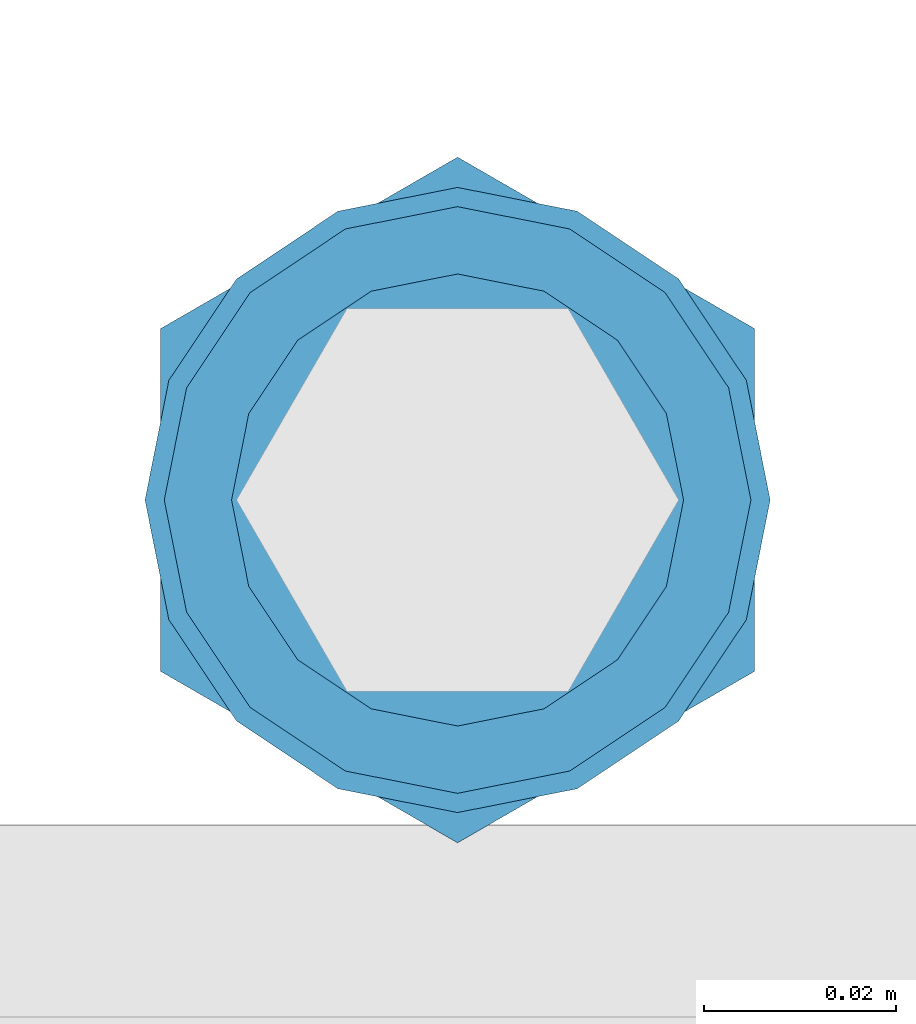
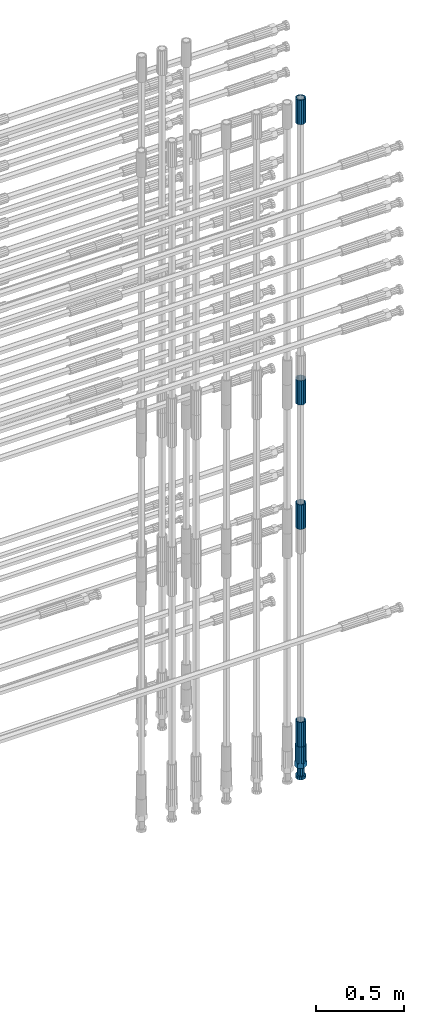
# One storey, part 102 of 119: 5 beams.
"""IFC2X3 building model written with IfcOpenShell, lengths in millimetres."""

from ifc_helpers import new_model, si_unit, frame, origin_with_axes, place, context, subcontext, project, spatial, faceted_brep, material, type_object, element, save


model = new_model("IFC2X3")

# Units and contexts
model_context = context("Model", 3, precision=1e-05, world=origin_with_axes())
body_context = subcontext(model_context, "Body", "Model", "MODEL_VIEW")
ifc_project = project(units=[si_unit("LENGTHUNIT", "METRE", prefix="MILLI"), si_unit("AREAUNIT", "SQUARE_METRE"), si_unit("VOLUMEUNIT", "CUBIC_METRE"), si_unit("MASSUNIT", "GRAM", prefix="KILO"), si_unit("TIMEUNIT", "SECOND"), si_unit("PLANEANGLEUNIT", "RADIAN"), si_unit("SOLIDANGLEUNIT", "STERADIAN"), si_unit("THERMODYNAMICTEMPERATUREUNIT", "DEGREE_CELSIUS"), si_unit("LUMINOUSINTENSITYUNIT", "LUMEN")], contexts=[model_context])

# Site, building, storey
site_placement = place(None, origin_with_axes())
site = spatial("IfcSite", under=ifc_project, at=site_placement, CompositionType="ELEMENT")
building_placement = place(site_placement, origin_with_axes())
building = spatial("IfcBuilding", under=site, at=building_placement, Name="Undefined", CompositionType="ELEMENT")
storey_placement = place(building_placement, origin_with_axes())
storey = spatial("IfcBuildingStorey", under=building, at=storey_placement, Name="Undefined", CompositionType="ELEMENT", Elevation=0.0)

# Beams
ifc_material = material(Name="STEEL/S275")
beam_type_1 = type_object("IfcBeamType", PredefinedType="NOTDEFINED")
beam_1_placement = place(storey_placement, frame((2039119.0136987, 6205156.73095221, 18490.9668583139), z_axis=(-0.99999999999998, 1.98000110685822e-07, 0.0), x_axis=(0.0, 0.0, -1.0)))
element("IfcBeam", 1, at=beam_1_placement, inside=storey, type_object=beam_type_1, material=ifc_material, Name="AG40N", context=body_context, shape_type="Brep", body=[
    faceted_brep([(1.62981450557709e-09, -23.4999999990687, 0.0), (7.45058059692383e-09, -21.7111690142192, 8.99306066057534), (170.000002125278, -21.711168999318, 8.99306066022245), (170.000002127141, -23.4999999844003, -3.66071617463604e-10), (4.65661287307739e-09, -16.6170093587134, 16.6170093578889), (170.000002122484, -16.6170093440451, 16.6170093575288), (1.86264514923096e-09, -8.99306066217832, 21.7111690140277), (170.000002118759, -8.99306064750999, 21.7111690136603), (2.3283064365387e-10, 9.31322574615479e-10, 23.5), (170.000002114102, 1.28056854009628e-08, 23.4999999996485), (-6.51925802230835e-09, 8.99306065868586, 21.7111690140241), (170.00000211224, 8.99306067335419, 21.7111690136639), (-7.45058059692383e-09, 16.6170093561523, 16.6170093578853), (170.000002109446, 16.6170093708206, 16.6170093575324), (-9.31322574615479e-09, 21.711169013055, 8.99306066057534), (170.000002108514, 21.7111690277234, 8.99306066022245), (-1.16415321826935e-09, 23.5000000009313, 0.0), (170.000002108514, 23.5000000144355, -3.66071617463604e-10), (-8.38190317153931e-09, 21.7111690151505, -8.99306066059444), (170.000002110377, 21.7111690300517, -8.9930606609546), (-5.58793544769287e-09, 16.6170093598776, -16.6170093579008), (170.000002113171, 16.6170093745459, -16.6170093582609), (-9.31322574615479e-10, 8.99306066334248, -21.7111690140396), (170.000002115965, 8.99306067801081, -21.7111690143961), (2.3283064365387e-10, 9.31322574615479e-10, -23.5), (170.00000211969, 1.7927959561348e-08, -23.5000000003843), (5.58793544769287e-09, -8.99306065752171, -21.7111690140396), (170.000002123415, -8.99306064285338, -21.7111690143961), (8.38190317153931e-09, -16.6170093549881, -16.6170093579008), (170.000002125278, -16.6170093403198, -16.6170093582646), (9.31322574615479e-09, -21.7111690121237, -8.99306066059444), (170.000002127141, -21.7111689972226, -8.9930606609546), (1.11758708953857e-08, -30.4999999990687, -9.54969436861575e-12), (1.30385160446167e-08, -28.1783257392235, -11.6718446871514), (170.000002129003, -28.1783257243223, -11.6718446875116), (170.000002129935, -30.4999999841675, -3.66071617463604e-10), (1.02445483207703e-08, -21.5667568228673, -21.5667568262129), (170.000002128072, -21.566756808199, -21.5667568265694), (7.45058059692383e-09, -11.6718446831219, -28.1783257416196), (170.000002125278, -11.6718446684536, -28.1783257419834), (3.72529029846191e-09, 3.95812094211578e-09, -30.5000000000277), (170.00000211969, 1.83936208486557e-08, -30.5000000003879), (-9.31322574615479e-10, 11.6718446905725, -28.1783257416232), (170.000002115965, 11.6718447052408, -28.1783257419797), (-6.51925802230835e-09, 21.5667568286881, -21.5667568262093), (170.000002110377, 21.5667568433564, -21.5667568265694), (-9.31322574615479e-09, 28.178325742716, -11.6718446871478), (170.000002108514, 28.1783257573843, -11.6718446875079), (-1.21071934700012e-08, 30.5, -5.91171556152403e-12), (170.000002106652, 30.5000000144355, -3.62433638656512e-10), (-1.21071934700012e-08, 28.1783257401548, 11.6718446871359), (170.00000210572, 28.1783257548232, 11.6718446867794), (-1.02445483207703e-08, 21.5667568240315, 21.5667568261974), (170.000002107583, 21.566756838467, 21.5667568258409), (-7.45058059692383e-09, 11.671844684286, 28.1783257416041), (170.000002110377, 11.6718446989544, 28.178325741244), (-2.79396772384644e-09, -2.56113708019257e-09, 30.5000000000159), (170.000002114102, 1.18743628263474e-08, 30.4999999996558), (1.86264514923096e-09, -11.6718446896411, 28.1783257416114), (170.000002118759, -11.67184467474, 28.178325741244), (7.45058059692383e-09, -21.5667568275239, 21.5667568261974), (170.000002123415, -21.5667568126228, 21.5667568258373), (1.02445483207703e-08, -28.1783257415518, 11.6718446871359), (170.000002127141, -28.1783257271163, 11.6718446867794)], [[[0, 1, 2, 3]], [[1, 4, 5, 2]], [[4, 6, 7, 5]], [[6, 8, 9, 7]], [[8, 10, 11, 9]], [[10, 12, 13, 11]], [[12, 14, 15, 13]], [[14, 16, 17, 15]], [[16, 18, 19, 17]], [[18, 20, 21, 19]], [[20, 22, 23, 21]], [[22, 24, 25, 23]], [[24, 26, 27, 25]], [[26, 28, 29, 27]], [[28, 30, 31, 29]], [[30, 0, 3, 31]], [[32, 33, 34, 35]], [[33, 36, 37, 34]], [[36, 38, 39, 37]], [[38, 40, 41, 39]], [[40, 42, 43, 41]], [[42, 44, 45, 43]], [[44, 46, 47, 45]], [[46, 48, 49, 47]], [[48, 50, 51, 49]], [[50, 52, 53, 51]], [[52, 54, 55, 53]], [[54, 56, 57, 55]], [[56, 58, 59, 57]], [[58, 60, 61, 59]], [[60, 62, 63, 61]], [[62, 32, 35, 63]], [[37, 39, 41, 43, 45, 47, 49, 51, 53, 55, 57, 59, 61, 63, 35, 34], [5, 7, 9, 11, 13, 15, 17, 19, 21, 23, 25, 27, 29, 31, 3, 2]], [[62, 60, 58, 56, 54, 52, 50, 48, 46, 44, 42, 40, 38, 36, 33, 32], [30, 28, 26, 24, 22, 20, 18, 16, 14, 12, 10, 8, 6, 4, 1, 0]]]),
])
beam_2_placement = place(storey_placement, frame((2039119.0136987, 6205156.73095221, 20704.605729163), z_axis=(1.0, 0.0, 0.0), x_axis=(0.0, 0.0, 1.0)))
element("IfcBeam", 2, at=beam_2_placement, inside=storey, type_object=beam_type_1, material=ifc_material, Name="AG40N", context=body_context, shape_type="Brep", body=[
    faceted_brep([(1.62981450557709e-09, -23.4999999990687, 0.0), (7.45058059692383e-09, -21.7111690142192, 8.99306066057534), (170.000002125278, -21.711168999318, 8.99306066022245), (170.000002127141, -23.4999999844003, -3.66071617463604e-10), (4.65661287307739e-09, -16.6170093587134, 16.6170093578889), (170.000002122484, -16.6170093440451, 16.6170093575288), (1.86264514923096e-09, -8.99306066217832, 21.7111690140277), (170.000002118759, -8.99306064750999, 21.7111690136603), (2.3283064365387e-10, 9.31322574615479e-10, 23.5), (170.000002114102, 1.28056854009628e-08, 23.4999999996485), (-6.51925802230835e-09, 8.99306065868586, 21.7111690140241), (170.00000211224, 8.99306067335419, 21.7111690136639), (-7.45058059692383e-09, 16.6170093561523, 16.6170093578853), (170.000002109446, 16.6170093708206, 16.6170093575324), (-9.31322574615479e-09, 21.711169013055, 8.99306066057534), (170.000002108514, 21.7111690277234, 8.99306066022245), (-1.16415321826935e-09, 23.5000000009313, 0.0), (170.000002108514, 23.5000000144355, -3.66071617463604e-10), (-8.38190317153931e-09, 21.7111690151505, -8.99306066059444), (170.000002110377, 21.7111690300517, -8.9930606609546), (-5.58793544769287e-09, 16.6170093598776, -16.6170093579008), (170.000002113171, 16.6170093745459, -16.6170093582609), (-9.31322574615479e-10, 8.99306066334248, -21.7111690140396), (170.000002115965, 8.99306067801081, -21.7111690143961), (2.3283064365387e-10, 9.31322574615479e-10, -23.5), (170.00000211969, 1.7927959561348e-08, -23.5000000003843), (5.58793544769287e-09, -8.99306065752171, -21.7111690140396), (170.000002123415, -8.99306064285338, -21.7111690143961), (8.38190317153931e-09, -16.6170093549881, -16.6170093579008), (170.000002125278, -16.6170093403198, -16.6170093582646), (9.31322574615479e-09, -21.7111690121237, -8.99306066059444), (170.000002127141, -21.7111689972226, -8.9930606609546), (1.11758708953857e-08, -30.4999999990687, -9.54969436861575e-12), (1.30385160446167e-08, -28.1783257392235, -11.6718446871514), (170.000002129003, -28.1783257243223, -11.6718446875116), (170.000002129935, -30.4999999841675, -3.66071617463604e-10), (1.02445483207703e-08, -21.5667568228673, -21.5667568262129), (170.000002128072, -21.566756808199, -21.5667568265694), (7.45058059692383e-09, -11.6718446831219, -28.1783257416196), (170.000002125278, -11.6718446684536, -28.1783257419834), (3.72529029846191e-09, 3.95812094211578e-09, -30.5000000000277), (170.00000211969, 1.83936208486557e-08, -30.5000000003879), (-9.31322574615479e-10, 11.6718446905725, -28.1783257416232), (170.000002115965, 11.6718447052408, -28.1783257419797), (-6.51925802230835e-09, 21.5667568286881, -21.5667568262093), (170.000002110377, 21.5667568433564, -21.5667568265694), (-9.31322574615479e-09, 28.178325742716, -11.6718446871478), (170.000002108514, 28.1783257573843, -11.6718446875079), (-1.21071934700012e-08, 30.5, -5.91171556152403e-12), (170.000002106652, 30.5000000144355, -3.62433638656512e-10), (-1.21071934700012e-08, 28.1783257401548, 11.6718446871359), (170.00000210572, 28.1783257548232, 11.6718446867794), (-1.02445483207703e-08, 21.5667568240315, 21.5667568261974), (170.000002107583, 21.566756838467, 21.5667568258409), (-7.45058059692383e-09, 11.671844684286, 28.1783257416041), (170.000002110377, 11.6718446989544, 28.178325741244), (-2.79396772384644e-09, -2.56113708019257e-09, 30.5000000000159), (170.000002114102, 1.18743628263474e-08, 30.4999999996558), (1.86264514923096e-09, -11.6718446896411, 28.1783257416114), (170.000002118759, -11.67184467474, 28.178325741244), (7.45058059692383e-09, -21.5667568275239, 21.5667568261974), (170.000002123415, -21.5667568126228, 21.5667568258373), (1.02445483207703e-08, -28.1783257415518, 11.6718446871359), (170.000002127141, -28.1783257271163, 11.6718446867794)], [[[0, 1, 2, 3]], [[1, 4, 5, 2]], [[4, 6, 7, 5]], [[6, 8, 9, 7]], [[8, 10, 11, 9]], [[10, 12, 13, 11]], [[12, 14, 15, 13]], [[14, 16, 17, 15]], [[16, 18, 19, 17]], [[18, 20, 21, 19]], [[20, 22, 23, 21]], [[22, 24, 25, 23]], [[24, 26, 27, 25]], [[26, 28, 29, 27]], [[28, 30, 31, 29]], [[30, 0, 3, 31]], [[32, 33, 34, 35]], [[33, 36, 37, 34]], [[36, 38, 39, 37]], [[38, 40, 41, 39]], [[40, 42, 43, 41]], [[42, 44, 45, 43]], [[44, 46, 47, 45]], [[46, 48, 49, 47]], [[48, 50, 51, 49]], [[50, 52, 53, 51]], [[52, 54, 55, 53]], [[54, 56, 57, 55]], [[56, 58, 59, 57]], [[58, 60, 61, 59]], [[60, 62, 63, 61]], [[62, 32, 35, 63]], [[37, 39, 41, 43, 45, 47, 49, 51, 53, 55, 57, 59, 61, 63, 35, 34], [5, 7, 9, 11, 13, 15, 17, 19, 21, 23, 25, 27, 29, 31, 3, 2]], [[62, 60, 58, 56, 54, 52, 50, 48, 46, 44, 42, 40, 38, 36, 33, 32], [30, 28, 26, 24, 22, 20, 18, 16, 14, 12, 10, 8, 6, 4, 1, 0]]]),
])
beam_3_placement = place(storey_placement, frame((2039119.0136987, 6205156.73095221, 20007.7168583139), z_axis=(-0.99999999999998, 1.98000110685822e-07, 0.0), x_axis=(0.0, 0.0, -1.0)))
element("IfcBeam", 3, at=beam_3_placement, inside=storey, type_object=beam_type_1, material=ifc_material, Name="AG40N", context=body_context, shape_type="Brep", body=[
    faceted_brep([(1.62981450557709e-09, -23.4999999990687, 0.0), (7.45058059692383e-09, -21.7111690142192, 8.99306066057534), (170.000002125278, -21.711168999318, 8.99306066022245), (170.000002127141, -23.4999999844003, -3.66071617463604e-10), (4.65661287307739e-09, -16.6170093587134, 16.6170093578889), (170.000002122484, -16.6170093440451, 16.6170093575288), (1.86264514923096e-09, -8.99306066217832, 21.7111690140277), (170.000002118759, -8.99306064750999, 21.7111690136603), (2.3283064365387e-10, 9.31322574615479e-10, 23.5), (170.000002114102, 1.28056854009628e-08, 23.4999999996485), (-6.51925802230835e-09, 8.99306065868586, 21.7111690140241), (170.00000211224, 8.99306067335419, 21.7111690136639), (-7.45058059692383e-09, 16.6170093561523, 16.6170093578853), (170.000002109446, 16.6170093708206, 16.6170093575324), (-9.31322574615479e-09, 21.711169013055, 8.99306066057534), (170.000002108514, 21.7111690277234, 8.99306066022245), (-1.16415321826935e-09, 23.5000000009313, 0.0), (170.000002108514, 23.5000000144355, -3.66071617463604e-10), (-8.38190317153931e-09, 21.7111690151505, -8.99306066059444), (170.000002110377, 21.7111690300517, -8.9930606609546), (-5.58793544769287e-09, 16.6170093598776, -16.6170093579008), (170.000002113171, 16.6170093745459, -16.6170093582609), (-9.31322574615479e-10, 8.99306066334248, -21.7111690140396), (170.000002115965, 8.99306067801081, -21.7111690143961), (2.3283064365387e-10, 9.31322574615479e-10, -23.5), (170.00000211969, 1.7927959561348e-08, -23.5000000003843), (5.58793544769287e-09, -8.99306065752171, -21.7111690140396), (170.000002123415, -8.99306064285338, -21.7111690143961), (8.38190317153931e-09, -16.6170093549881, -16.6170093579008), (170.000002125278, -16.6170093403198, -16.6170093582646), (9.31322574615479e-09, -21.7111690121237, -8.99306066059444), (170.000002127141, -21.7111689972226, -8.9930606609546), (1.11758708953857e-08, -30.4999999990687, -9.54969436861575e-12), (1.30385160446167e-08, -28.1783257392235, -11.6718446871514), (170.000002129003, -28.1783257243223, -11.6718446875116), (170.000002129935, -30.4999999841675, -3.66071617463604e-10), (1.02445483207703e-08, -21.5667568228673, -21.5667568262129), (170.000002128072, -21.566756808199, -21.5667568265694), (7.45058059692383e-09, -11.6718446831219, -28.1783257416196), (170.000002125278, -11.6718446684536, -28.1783257419834), (3.72529029846191e-09, 3.95812094211578e-09, -30.5000000000277), (170.00000211969, 1.83936208486557e-08, -30.5000000003879), (-9.31322574615479e-10, 11.6718446905725, -28.1783257416232), (170.000002115965, 11.6718447052408, -28.1783257419797), (-6.51925802230835e-09, 21.5667568286881, -21.5667568262093), (170.000002110377, 21.5667568433564, -21.5667568265694), (-9.31322574615479e-09, 28.178325742716, -11.6718446871478), (170.000002108514, 28.1783257573843, -11.6718446875079), (-1.21071934700012e-08, 30.5, -5.91171556152403e-12), (170.000002106652, 30.5000000144355, -3.62433638656512e-10), (-1.21071934700012e-08, 28.1783257401548, 11.6718446871359), (170.00000210572, 28.1783257548232, 11.6718446867794), (-1.02445483207703e-08, 21.5667568240315, 21.5667568261974), (170.000002107583, 21.566756838467, 21.5667568258409), (-7.45058059692383e-09, 11.671844684286, 28.1783257416041), (170.000002110377, 11.6718446989544, 28.178325741244), (-2.79396772384644e-09, -2.56113708019257e-09, 30.5000000000159), (170.000002114102, 1.18743628263474e-08, 30.4999999996558), (1.86264514923096e-09, -11.6718446896411, 28.1783257416114), (170.000002118759, -11.67184467474, 28.178325741244), (7.45058059692383e-09, -21.5667568275239, 21.5667568261974), (170.000002123415, -21.5667568126228, 21.5667568258373), (1.02445483207703e-08, -28.1783257415518, 11.6718446871359), (170.000002127141, -28.1783257271163, 11.6718446867794)], [[[0, 1, 2, 3]], [[1, 4, 5, 2]], [[4, 6, 7, 5]], [[6, 8, 9, 7]], [[8, 10, 11, 9]], [[10, 12, 13, 11]], [[12, 14, 15, 13]], [[14, 16, 17, 15]], [[16, 18, 19, 17]], [[18, 20, 21, 19]], [[20, 22, 23, 21]], [[22, 24, 25, 23]], [[24, 26, 27, 25]], [[26, 28, 29, 27]], [[28, 30, 31, 29]], [[30, 0, 3, 31]], [[32, 33, 34, 35]], [[33, 36, 37, 34]], [[36, 38, 39, 37]], [[38, 40, 41, 39]], [[40, 42, 43, 41]], [[42, 44, 45, 43]], [[44, 46, 47, 45]], [[46, 48, 49, 47]], [[48, 50, 51, 49]], [[50, 52, 53, 51]], [[52, 54, 55, 53]], [[54, 56, 57, 55]], [[56, 58, 59, 57]], [[58, 60, 61, 59]], [[60, 62, 63, 61]], [[62, 32, 35, 63]], [[37, 39, 41, 43, 45, 47, 49, 51, 53, 55, 57, 59, 61, 63, 35, 34], [5, 7, 9, 11, 13, 15, 17, 19, 21, 23, 25, 27, 29, 31, 3, 2]], [[62, 60, 58, 56, 54, 52, 50, 48, 46, 44, 42, 40, 38, 36, 33, 32], [30, 28, 26, 24, 22, 20, 18, 16, 14, 12, 10, 8, 6, 4, 1, 0]]]),
])
beam_4_placement = place(storey_placement, frame((2039119.0136987, 6205156.73095221, 22659.985729163), z_axis=(1.0, 0.0, 0.0), x_axis=(0.0, 0.0, 1.0)))
element("IfcBeam", 4, at=beam_4_placement, inside=storey, type_object=beam_type_1, material=ifc_material, Name="AG40N", context=body_context, shape_type="Brep", body=[
    faceted_brep([(1.62981450557709e-09, -23.4999999990687, 0.0), (7.45058059692383e-09, -21.7111690142192, 8.99306066057534), (170.000002125278, -21.711168999318, 8.99306066022245), (170.000002127141, -23.4999999844003, -3.66071617463604e-10), (4.65661287307739e-09, -16.6170093587134, 16.6170093578889), (170.000002122484, -16.6170093440451, 16.6170093575288), (1.86264514923096e-09, -8.99306066217832, 21.7111690140277), (170.000002118759, -8.99306064750999, 21.7111690136603), (2.3283064365387e-10, 9.31322574615479e-10, 23.5), (170.000002114102, 1.28056854009628e-08, 23.4999999996485), (-6.51925802230835e-09, 8.99306065868586, 21.7111690140241), (170.00000211224, 8.99306067335419, 21.7111690136639), (-7.45058059692383e-09, 16.6170093561523, 16.6170093578853), (170.000002109446, 16.6170093708206, 16.6170093575324), (-9.31322574615479e-09, 21.711169013055, 8.99306066057534), (170.000002108514, 21.7111690277234, 8.99306066022245), (-1.16415321826935e-09, 23.5000000009313, 0.0), (170.000002108514, 23.5000000144355, -3.66071617463604e-10), (-8.38190317153931e-09, 21.7111690151505, -8.99306066059444), (170.000002110377, 21.7111690300517, -8.9930606609546), (-5.58793544769287e-09, 16.6170093598776, -16.6170093579008), (170.000002113171, 16.6170093745459, -16.6170093582609), (-9.31322574615479e-10, 8.99306066334248, -21.7111690140396), (170.000002115965, 8.99306067801081, -21.7111690143961), (2.3283064365387e-10, 9.31322574615479e-10, -23.5), (170.00000211969, 1.7927959561348e-08, -23.5000000003843), (5.58793544769287e-09, -8.99306065752171, -21.7111690140396), (170.000002123415, -8.99306064285338, -21.7111690143961), (8.38190317153931e-09, -16.6170093549881, -16.6170093579008), (170.000002125278, -16.6170093403198, -16.6170093582646), (9.31322574615479e-09, -21.7111690121237, -8.99306066059444), (170.000002127141, -21.7111689972226, -8.9930606609546), (1.11758708953857e-08, -30.4999999990687, -9.54969436861575e-12), (1.30385160446167e-08, -28.1783257392235, -11.6718446871514), (170.000002129003, -28.1783257243223, -11.6718446875116), (170.000002129935, -30.4999999841675, -3.66071617463604e-10), (1.02445483207703e-08, -21.5667568228673, -21.5667568262129), (170.000002128072, -21.566756808199, -21.5667568265694), (7.45058059692383e-09, -11.6718446831219, -28.1783257416196), (170.000002125278, -11.6718446684536, -28.1783257419834), (3.72529029846191e-09, 3.95812094211578e-09, -30.5000000000277), (170.00000211969, 1.83936208486557e-08, -30.5000000003879), (-9.31322574615479e-10, 11.6718446905725, -28.1783257416232), (170.000002115965, 11.6718447052408, -28.1783257419797), (-6.51925802230835e-09, 21.5667568286881, -21.5667568262093), (170.000002110377, 21.5667568433564, -21.5667568265694), (-9.31322574615479e-09, 28.178325742716, -11.6718446871478), (170.000002108514, 28.1783257573843, -11.6718446875079), (-1.21071934700012e-08, 30.5, -5.91171556152403e-12), (170.000002106652, 30.5000000144355, -3.62433638656512e-10), (-1.21071934700012e-08, 28.1783257401548, 11.6718446871359), (170.00000210572, 28.1783257548232, 11.6718446867794), (-1.02445483207703e-08, 21.5667568240315, 21.5667568261974), (170.000002107583, 21.566756838467, 21.5667568258409), (-7.45058059692383e-09, 11.671844684286, 28.1783257416041), (170.000002110377, 11.6718446989544, 28.178325741244), (-2.79396772384644e-09, -2.56113708019257e-09, 30.5000000000159), (170.000002114102, 1.18743628263474e-08, 30.4999999996558), (1.86264514923096e-09, -11.6718446896411, 28.1783257416114), (170.000002118759, -11.67184467474, 28.178325741244), (7.45058059692383e-09, -21.5667568275239, 21.5667568261974), (170.000002123415, -21.5667568126228, 21.5667568258373), (1.02445483207703e-08, -28.1783257415518, 11.6718446871359), (170.000002127141, -28.1783257271163, 11.6718446867794)], [[[0, 1, 2, 3]], [[1, 4, 5, 2]], [[4, 6, 7, 5]], [[6, 8, 9, 7]], [[8, 10, 11, 9]], [[10, 12, 13, 11]], [[12, 14, 15, 13]], [[14, 16, 17, 15]], [[16, 18, 19, 17]], [[18, 20, 21, 19]], [[20, 22, 23, 21]], [[22, 24, 25, 23]], [[24, 26, 27, 25]], [[26, 28, 29, 27]], [[28, 30, 31, 29]], [[30, 0, 3, 31]], [[32, 33, 34, 35]], [[33, 36, 37, 34]], [[36, 38, 39, 37]], [[38, 40, 41, 39]], [[40, 42, 43, 41]], [[42, 44, 45, 43]], [[44, 46, 47, 45]], [[46, 48, 49, 47]], [[48, 50, 51, 49]], [[50, 52, 53, 51]], [[52, 54, 55, 53]], [[54, 56, 57, 55]], [[56, 58, 59, 57]], [[58, 60, 61, 59]], [[60, 62, 63, 61]], [[62, 32, 35, 63]], [[37, 39, 41, 43, 45, 47, 49, 51, 53, 55, 57, 59, 61, 63, 35, 34], [5, 7, 9, 11, 13, 15, 17, 19, 21, 23, 25, 27, 29, 31, 3, 2]], [[62, 60, 58, 56, 54, 52, 50, 48, 46, 44, 42, 40, 38, 36, 33, 32], [30, 28, 26, 24, 22, 20, 18, 16, 14, 12, 10, 8, 6, 4, 1, 0]]]),
])
beam_type_2 = type_object("IfcBeamType", Name="ROD65", PredefinedType="NOTDEFINED")
beam_5_placement = place(storey_placement, frame((2039119.0136987, 6205156.73095221, 18320.9668583139), z_axis=(-0.99999999999998, 1.98000110685822e-07, 0.0), x_axis=(0.0, 0.0, -1.0)))
element("IfcBeam", 5, at=beam_5_placement, inside=storey, type_object=beam_type_2, material=ifc_material, Name="AGB40", ObjectType="ROD65", context=body_context, shape_type="Brep", body=[
    faceted_brep([(116.999999999069, 17.8249999252148, 30.8738056446964), (116.999999998137, 22.0056957420893, 23.632628078838), (116.999999999069, 12.4372115600854, 30.0260848066173), (116.999999999069, 8.17543111252598, 30.8738056446964), (117.000000000931, -17.8250000746921, 30.8738056446964), (150.200000001118, -17.8250000723638, 30.8738056446964), (150.199999999255, 17.8249999275431, 30.8738056446964), (117.000000000931, -8.17543109622784, 30.8738056446964), (117.000000001863, -22.0056959956419, 23.6326278985034), (117.000000000931, -12.4372115437873, 30.0260848066173), (117.000000001863, -35.6500000746455, -2.18278728425503e-10), (150.200000002049, -35.6500000723172, -2.18278728425503e-10), (117.000000001863, -30.8443149488885, 8.32369080289209), (117.000000001863, -30.8443149488885, -8.32369080355784), (117.000000002794, -32.4999999918509, 0.0), (117.000000000931, -17.8250000746921, -30.873805645133), (150.200000001118, -17.8250000723638, -30.873805645133), (117.000000001863, -22.0056959961075, -23.6326278982269), (117.000000000931, -8.17543109389953, -30.873805645133), (117.000000000931, -12.4372115437873, -30.0260848066173), (116.999999999069, 17.8249999252148, -30.873805645133), (150.199999999255, 17.8249999275431, -30.873805645133), (116.999999999069, 8.17543111019768, -30.873805645133), (116.999999999069, 12.4372115600854, -30.0260848066173), (116.999999998137, 22.005695742555, -23.6326280785652), (116.999999998137, 35.6499999251682, -2.18278728425503e-10), (150.199999998324, 35.6499999277294, -2.18278728425503e-10), (116.999999998137, 30.8443150522653, -8.32369036550881), (116.999999997206, 32.5000000081491, 0.0), (116.999999998137, 30.8443150522653, 8.32369036483942), (1.86264514923096e-09, -22.9809703885112, 22.9809703885621), (1.86264514923096e-09, -30.0260848065373, 12.4372115518672), (117.000000001863, -30.0260847983882, 12.4372115518672), (117.000000001863, -22.9809703803621, 22.9809703885621), (-1.86264514923096e-09, 22.9809703885112, -22.9809703885621), (-1.86264514923096e-09, 30.0260848065373, -12.4372115518672), (116.999999998137, 30.0260848146863, -12.4372115518672), (116.999999998137, 22.9809703966603, -22.9809703885621), (1.86264514923096e-09, -30.0260848065373, -12.4372115518672), (1.86264514923096e-09, -22.9809703885112, -22.9809703885621), (117.000000001863, -22.9809703803621, -22.9809703885621), (117.000000001863, -30.0260847983882, -12.4372115518672), (9.31322574615479e-10, -12.4372115519363, 30.0260848066173), (0.0, 0.0, 32.5), (-9.31322574615479e-10, 12.4372115519363, 30.0260848066173), (-1.86264514923096e-09, 22.9809703885112, 22.9809703885621), (-1.86264514923096e-09, 30.0260848065373, 12.4372115518672), (-2.79396772384644e-09, 32.5, 0.0), (-9.31322574615479e-10, 12.4372115519363, -30.0260848066173), (0.0, 0.0, -32.5), (9.31322574615479e-10, -12.4372115519363, -30.0260848066173), (2.79396772384644e-09, -32.5, 0.0), (116.999999998137, 22.9809703966603, 22.9809703885621), (116.999999998137, 30.0260848146863, 12.4372115518672), (117.0, 8.14907252788544e-09, -32.5), (117.0, 8.14907252788544e-09, 32.5), (150.200000000186, -10.5000000959262, 18.1865334791873), (150.199999999255, -9.59262251853943e-08, 20.9999999997126), (150.199999998324, 10.4999999040738, 18.1865334791873), (150.199999997392, 18.1865333835594, 10.4999999997126), (150.199999997392, 20.9999999040738, -2.87400325760245e-10), (150.199999997392, 18.1865333835594, -10.5000000002874), (150.199999998324, 10.4999999040738, -18.1865334797621), (150.199999999255, -9.59262251853943e-08, -21.0000000002874), (150.200000000186, -10.5000000959262, -18.1865334797621), (150.200000000186, -18.1865335754119, -10.5000000002874), (150.200000001118, -21.0000000959262, -2.87400325760245e-10), (150.200000000186, -18.1865335754119, 10.4999999997126), (210.979999999516, 10.4999999082647, 18.1865334791873), (210.979999999516, -9.17352735996246e-08, 20.9999999997126), (210.979999997653, 18.1865333877504, 10.4999999997126), (210.979999997653, 20.9999999082647, -2.87400325760245e-10), (210.979999997653, 18.1865333877504, -10.5000000002874), (210.979999999516, 10.4999999082647, -18.1865334797621), (210.979999999516, -9.17352735996246e-08, -21.0000000002874), (210.979999999516, -10.5000000917353, -18.1865334797621), (210.980000000447, -18.1865335712209, -10.5000000002874), (210.980000001378, -21.0000000917353, -2.87400325760245e-10), (210.980000000447, -18.1865335712209, 10.4999999997126), (210.979999999516, -10.5000000917353, 18.1865334791873), (211.001368402503, -27.7269939335529, -11.4911163272045), (211.003082515672, -21.2238095656503, -21.2238154190527), (231.002518340945, -21.2131946226582, -21.2132004554769), (231.000804228708, -27.7163789905608, -11.4805013636287), (211.001368415542, -11.4911086384673, -27.7269970399575), (231.000804241747, -11.4804936954752, -27.7163820763781), (210.996487061493, -0.0106066407170147, -30.0106107396168), (230.995922887698, 8.30227509140968e-06, -29.999995776041), (210.98918159306, 11.4698940692469, -27.7269970332745), (230.988617419265, 11.4805090120062, -27.7163820696951), (210.980564201251, 21.2025913291145, -21.2238154067054), (230.980000027455, 21.2132062721066, -21.2132004431296), (210.971946807578, 27.7057702087332, -11.4911163110701), (230.971382633783, 27.7163851517253, -11.4805013474943), (210.964641331695, 29.9893806746695, -0.0106149565435771), (230.9640771579, 29.9999956176616, 7.03221303410828e-09), (210.959759964608, 27.7057637346443, 11.4698863966551), (230.959195790812, 27.7163786776364, 11.4805013602345), (210.958045851439, 21.2025793667417, 21.2025854885032), (230.957481677644, 21.2131943097338, 21.2132004520827), (210.959759951569, 11.4698784395587, 27.705767109408), (230.959195776843, 11.4804933823179, 27.7163820729838), (210.964641305618, -0.0106235581915826, 29.9893808090674), (230.964077131823, -8.61519947648048e-06, 29.9999957726432), (210.971946774051, -11.4911242681555, 27.7057671027251), (230.971382599324, -11.4805093251634, 27.7163820663009), (210.98056416586, -21.2238215280231, 21.2025854761559), (230.979999991134, -21.2132065852638, 21.2132004397354), (210.989181559533, -27.7270004076418, 11.4698863805206), (230.988617384806, -27.7163854646496, 11.4805013441), (210.996487035416, -30.0106108735781, -0.0106149740058754), (230.995922861621, -29.999995930586, -1.04300852399319e-08)], [[[0, 1, 2, 3]], [[4, 5, 6, 0, 3, 7]], [[8, 4, 7, 9]], [[10, 11, 5, 4, 8, 12]], [[13, 10, 12, 14]], [[15, 16, 11, 10, 13, 17]], [[18, 15, 17, 19]], [[20, 21, 16, 15, 18, 22]], [[20, 22, 23, 24]], [[25, 26, 21, 20, 24, 27]], [[25, 27, 28, 29]], [[30, 31, 32, 33]], [[34, 35, 36, 37]], [[38, 39, 40, 41]], [[31, 30, 42, 43, 44, 45, 46, 47, 35, 34, 48, 49, 50, 39, 38, 51]], [[46, 45, 52, 53]], [[28, 47, 46, 53, 29]], [[27, 36, 35, 47, 28]], [[24, 37, 36, 27]], [[23, 48, 34, 37, 24]], [[22, 54, 49, 48, 23]], [[18, 54, 22]], [[19, 50, 49, 54, 18]], [[17, 40, 39, 50, 19]], [[13, 41, 40, 17]], [[14, 51, 38, 41, 13]], [[12, 32, 31, 51, 14]], [[8, 33, 32, 12]], [[9, 42, 30, 33, 8]], [[7, 55, 43, 42, 9]], [[3, 55, 7]], [[2, 44, 43, 55, 3]], [[1, 52, 45, 44, 2]], [[29, 53, 52, 1]], [[0, 6, 26, 25, 29, 1]], [[5, 11, 16, 21, 26, 6], [56, 57, 58, 59, 60, 61, 62, 63, 64, 65, 66, 67]], [[68, 58, 57, 69]], [[70, 59, 58, 68]], [[71, 60, 59, 70]], [[72, 61, 60, 71]], [[73, 62, 61, 72]], [[74, 63, 62, 73]], [[75, 64, 63, 74]], [[76, 65, 64, 75]], [[77, 66, 65, 76]], [[78, 67, 66, 77]], [[79, 56, 67, 78]], [[69, 57, 56, 79]], [[80, 81, 82, 83]], [[81, 84, 85, 82]], [[84, 86, 87, 85]], [[86, 88, 89, 87]], [[88, 90, 91, 89]], [[90, 92, 93, 91]], [[92, 94, 95, 93]], [[94, 96, 97, 95]], [[96, 98, 99, 97]], [[98, 100, 101, 99]], [[100, 102, 103, 101]], [[102, 104, 105, 103]], [[104, 106, 107, 105]], [[106, 108, 109, 107]], [[108, 110, 111, 109]], [[82, 85, 87, 89, 91, 93, 95, 97, 99, 101, 103, 105, 107, 109, 111, 83]], [[110, 80, 83, 111]], [[108, 106, 104, 102, 100, 98, 96, 94, 92, 90, 88, 86, 84, 81, 80, 110], [78, 77, 76, 75, 74, 73, 72, 71, 70, 68, 69, 79]]]),
])

save(model, "model.ifc")
